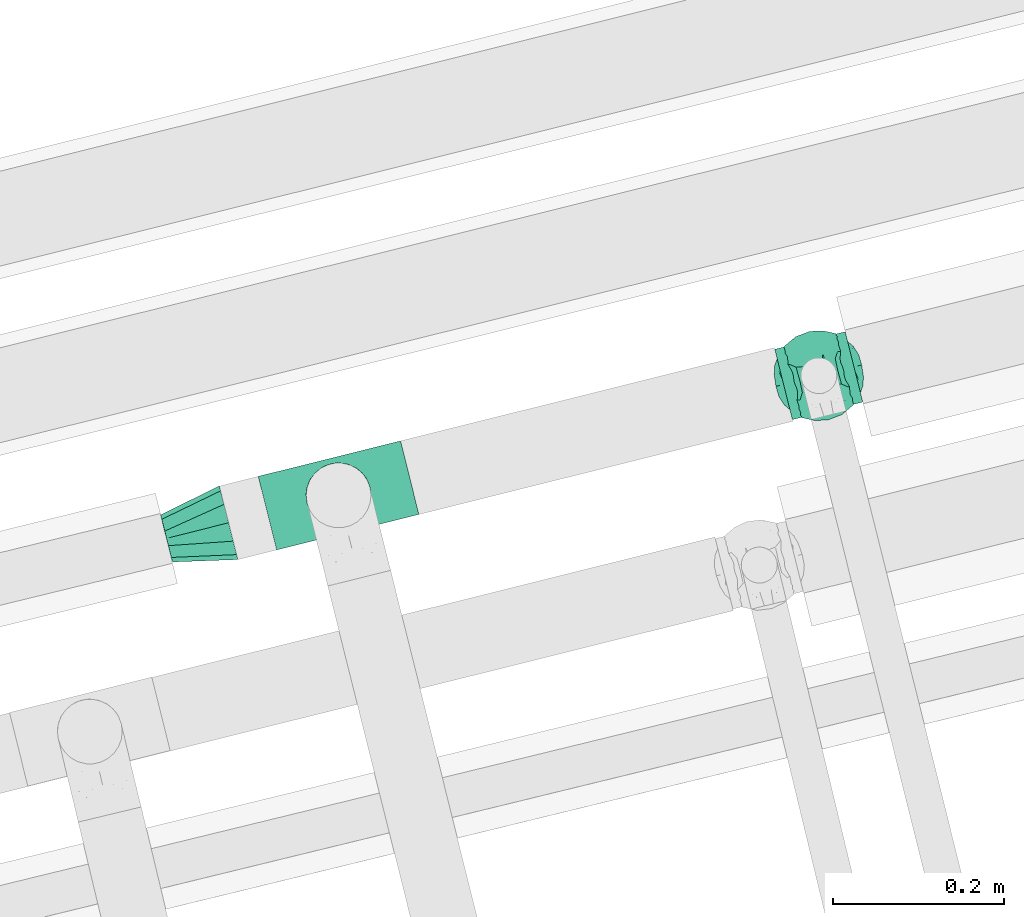
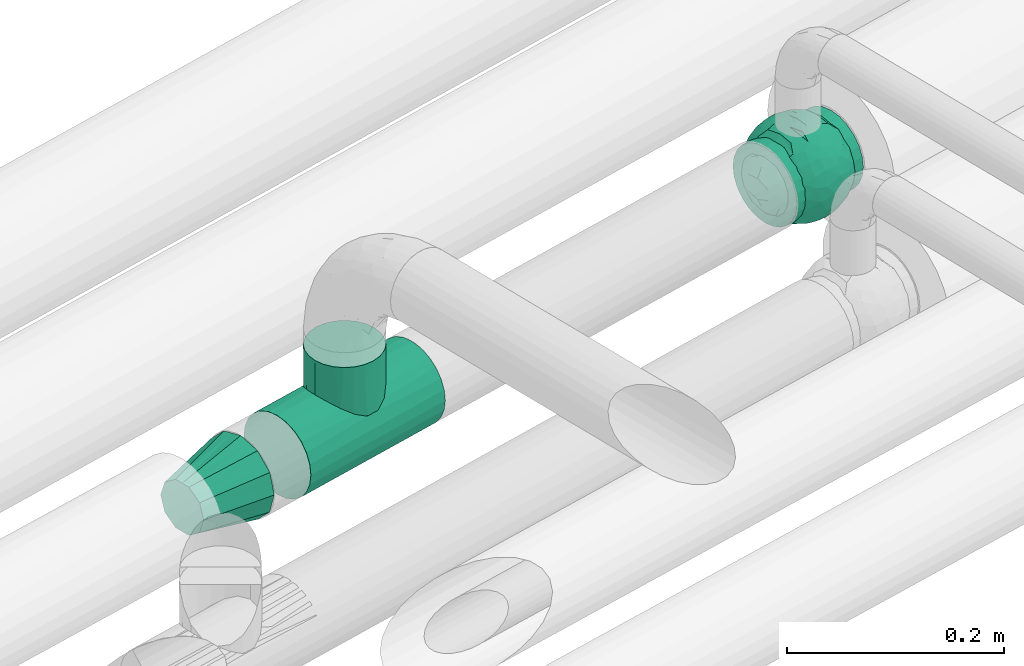
# One storey, part 88 of 93: 3 flow fittings.
"""IFC2X3 building model written with IfcOpenShell, lengths in millimetres."""

from ifc_helpers import new_model, entity, si_unit, converted_unit, derived_unit, direction, frame, origin, place, context, subcontext, project, spatial, faceted_brep, source, transform, mapped, material, material_list, type_object, type_shapes, element, save


model = new_model("IFC2X3")

# Units and contexts
model_context = context("Model", 3, precision=0.01, world=origin(), true_north=direction((6.12303176911189e-17, 1.0)))
body_context = subcontext(model_context, "Body", "Model", "MODEL_VIEW")
ifc_project = project(units=[si_unit("LENGTHUNIT", "METRE", prefix="MILLI"), si_unit("AREAUNIT", "SQUARE_METRE"), si_unit("VOLUMEUNIT", "CUBIC_METRE"), converted_unit("PLANEANGLEUNIT", "DEGREE", entity("IfcRatioMeasure", 0.0174532925199433), si_unit("PLANEANGLEUNIT", "RADIAN"), dimensions=[0, 0, 0, 0, 0, 0, 0]), si_unit("MASSUNIT", "GRAM", prefix="KILO"), derived_unit("MASSDENSITYUNIT", [(si_unit("MASSUNIT", "GRAM", prefix="KILO"), 1), (si_unit("LENGTHUNIT", "METRE"), -3)]), derived_unit("MOMENTOFINERTIAUNIT", [(si_unit("LENGTHUNIT", "METRE"), 4)]), si_unit("TIMEUNIT", "SECOND"), si_unit("FREQUENCYUNIT", "HERTZ"), si_unit("THERMODYNAMICTEMPERATUREUNIT", "DEGREE_CELSIUS"), derived_unit("THERMALTRANSMITTANCEUNIT", [(si_unit("MASSUNIT", "GRAM", prefix="KILO"), 1), (si_unit("THERMODYNAMICTEMPERATUREUNIT", "KELVIN"), -1), (si_unit("TIMEUNIT", "SECOND"), -3)]), derived_unit("VOLUMETRICFLOWRATEUNIT", [(si_unit("LENGTHUNIT", "METRE"), 3), (si_unit("TIMEUNIT", "SECOND"), -1)]), derived_unit("MASSFLOWRATEUNIT", [(si_unit("MASSUNIT", "GRAM", prefix="KILO"), 1), (si_unit("TIMEUNIT", "SECOND"), -1)]), derived_unit("ROTATIONALFREQUENCYUNIT", [(si_unit("TIMEUNIT", "SECOND"), -1)]), si_unit("ELECTRICCURRENTUNIT", "AMPERE"), si_unit("ELECTRICVOLTAGEUNIT", "VOLT"), si_unit("POWERUNIT", "WATT"), si_unit("FORCEUNIT", "NEWTON", prefix="KILO"), si_unit("ILLUMINANCEUNIT", "LUX"), si_unit("LUMINOUSFLUXUNIT", "LUMEN"), si_unit("LUMINOUSINTENSITYUNIT", "CANDELA"), derived_unit("USERDEFINED", [(si_unit("MASSUNIT", "GRAM", prefix="KILO"), -1), (si_unit("LENGTHUNIT", "METRE"), -2), (si_unit("TIMEUNIT", "SECOND"), 3), (si_unit("LUMINOUSFLUXUNIT", "LUMEN"), 1)]), derived_unit("LINEARVELOCITYUNIT", [(si_unit("LENGTHUNIT", "METRE"), 1), (si_unit("TIMEUNIT", "SECOND"), -1)]), si_unit("PRESSUREUNIT", "PASCAL"), derived_unit("USERDEFINED", [(si_unit("LENGTHUNIT", "METRE"), -2), (si_unit("MASSUNIT", "GRAM", prefix="KILO"), 1), (si_unit("TIMEUNIT", "SECOND"), -2)]), derived_unit("LINEARFORCEUNIT", [(si_unit("MASSUNIT", "GRAM", prefix="KILO"), 1), (si_unit("LENGTHUNIT", "METRE"), 1), (si_unit("TIMEUNIT", "SECOND"), -2), (si_unit("LENGTHUNIT", "METRE"), -1)]), derived_unit("PLANARFORCEUNIT", [(si_unit("MASSUNIT", "GRAM", prefix="KILO"), 1), (si_unit("LENGTHUNIT", "METRE"), 1), (si_unit("TIMEUNIT", "SECOND"), -2), (si_unit("LENGTHUNIT", "METRE"), -2)])], contexts=[model_context])

# Site, building, storey
site_placement = place(None, origin())
site = spatial("IfcSite", under=ifc_project, at=site_placement, CompositionType="ELEMENT")
building_placement = place(site_placement, origin())
building = spatial("IfcBuilding", under=site, at=building_placement, CompositionType="ELEMENT")
storey_placement = place(building_placement, frame((0.0, 0.0, -4200.0)))
storey = spatial("IfcBuildingStorey", under=building, at=storey_placement, CompositionType="ELEMENT", Elevation=-4200.0)

# Flow fittings
ifc_material_1 = material()
ifc_material_2 = material(Name="ADSK_")
ifc_material_list = material_list([ifc_material_1, ifc_material_2])
pipe_fitting_type_1 = type_object("IfcPipeFittingType", Name="ADSK_1", PredefinedType="NOTDEFINED", material=ifc_material_list)
shared_shape_1 = source(origin(), body_context, "Body", "Brep", [
    faceted_brep([(-42.5, -11.0, -41.05), (-42.5, -21.25, -36.81), (-42.5, -30.05, -30.05), (-42.5, -36.81, -21.25), (-42.5, -41.05, -11.0), (-42.5, -42.5, 0.0), (-42.5, -41.05, 11.0), (-42.5, -36.81, 21.25), (-42.5, -30.05, 30.05), (-42.5, -21.25, 36.81), (-42.5, -11.0, 41.05), (-42.5, 0.0, 42.5), (-42.5, 11.0, 41.05), (-42.5, 21.25, 36.81), (-42.5, 30.05, 30.05), (-42.5, 36.81, 21.25), (-42.5, 41.05, 11.0), (-42.5, 41.78, 5.5), (-42.5, 42.5, 0.0), (-42.5, 41.78, -5.5), (-42.5, 41.05, -11.0), (-42.5, 36.81, -21.25), (-42.5, 30.05, -30.05), (-42.5, 21.25, -36.81), (-42.5, 11.0, -41.05), (-42.5, 0.0, -42.5), (42.5, 0.0, -42.5), (42.5, 11.0, -41.05), (42.5, 21.25, -36.81), (42.5, 30.05, -30.05), (42.5, 36.81, -21.25), (42.5, 41.05, -11.0), (42.5, 41.78, -5.5), (42.5, 42.5, 0.0), (42.5, 41.78, 5.5), (42.5, 41.05, 11.0), (42.5, 36.81, 21.25), (42.5, 30.05, 30.05), (42.5, 21.25, 36.81), (42.5, 11.0, 41.05), (42.5, 0.0, 42.5), (42.5, -11.0, 41.05), (42.5, -21.25, 36.81), (42.5, -30.05, 30.05), (42.5, -36.81, 21.25), (42.5, -41.05, 11.0), (42.5, -42.5, 0.0), (42.5, -41.05, -11.0), (42.5, -36.81, -21.25), (42.5, -30.05, -30.05), (42.5, -21.25, -36.81), (42.5, -11.0, -41.05), (17.36, 42.02, 6.38), (18.5, 42.5, 0.0), (-18.5, 42.5, 0.0), (14.15, 40.8, 11.92), (3.25, 38.4, 18.21), (9.29, 39.37, 16.0), (6.27, 38.89, 17.11), (17.93, 42.26, 3.19), (-17.36, 42.02, 6.38), (-17.93, 42.26, 3.19), (-14.16, 40.8, 11.91), (-3.25, 38.4, 18.21), (-6.27, 38.89, 17.1), (-9.29, 39.37, 16.0), (0.0, 38.4, 18.21), (-17.93, 42.26, -3.19), (-17.36, 42.02, -6.38), (3.25, 38.4, -18.21), (17.36, 42.02, -6.38), (6.27, 38.89, -17.11), (9.29, 39.37, -16.0), (14.15, 40.8, -11.92), (17.93, 42.26, -3.19), (-9.29, 39.37, -16.0), (-6.27, 38.89, -17.1), (-3.25, 38.4, -18.21), (0.0, 38.4, -18.21), (-14.16, 40.8, -11.91), (4.79, 47.5, -17.87), (0.0, 47.5, -18.5), (-4.79, 47.5, -17.87), (-9.25, 47.5, -16.02), (-13.08, 47.5, -13.08), (-16.02, 47.5, -9.25), (-17.87, 47.5, -4.79), (-18.5, 47.5, 0.0), (-17.87, 47.5, 4.79), (-16.02, 47.5, 9.25), (-13.08, 47.5, 13.08), (-9.25, 47.5, 16.02), (-4.79, 47.5, 17.87), (0.0, 47.5, 18.5), (4.79, 47.5, 17.87), (9.25, 47.5, 16.02), (13.08, 47.5, 13.08), (16.02, 47.5, 9.25), (17.87, 47.5, 4.79), (18.5, 47.5, 0.0), (17.87, 47.5, -4.79), (16.02, 47.5, -9.25), (13.08, 47.5, -13.08), (9.25, 47.5, -16.02)], [[[0, 1, 2, 3, 4, 5, 6, 7, 8, 9, 10, 11, 12, 13, 14, 15, 16, 17, 18, 19, 20, 21, 22, 23, 24, 25]], [[26, 27, 28, 29, 30, 31, 32, 33, 34, 35, 36, 37, 38, 39, 40, 41, 42, 43, 44, 45, 46, 47, 48, 49, 50, 51]], [[52, 35, 34]], [[34, 33, 53]], [[17, 54, 18]], [[52, 55, 35]], [[56, 37, 36]], [[57, 35, 55]], [[36, 57, 58, 56]], [[56, 14, 37]], [[36, 35, 57]], [[34, 53, 59, 52]], [[17, 60, 61, 54]], [[16, 62, 60]], [[15, 63, 64, 65]], [[65, 16, 15]], [[14, 63, 15]], [[62, 16, 65]], [[14, 56, 66, 63]], [[17, 16, 60]], [[14, 13, 38, 37]], [[40, 39, 12, 11]], [[39, 38, 13, 12]], [[41, 40, 11, 10]], [[6, 45, 44, 7]], [[43, 42, 9, 8]], [[44, 43, 8, 7]], [[9, 42, 41, 10]], [[46, 45, 6, 5]], [[47, 46, 5, 4]], [[2, 49, 48, 3]], [[48, 47, 4, 3]], [[24, 27, 26, 25]], [[51, 50, 1, 0]], [[51, 0, 25, 26]], [[1, 50, 49, 2]], [[28, 27, 24, 23]], [[19, 54, 67, 68]], [[23, 22, 29, 28]], [[69, 30, 29]], [[32, 31, 70]], [[30, 69, 71, 72]], [[72, 31, 30]], [[22, 69, 29]], [[32, 53, 33]], [[18, 54, 19]], [[31, 73, 70]], [[32, 70, 74, 53]], [[72, 73, 31]], [[21, 75, 76, 77]], [[77, 22, 21]], [[21, 20, 75]], [[22, 77, 78, 69]], [[20, 68, 79]], [[20, 19, 68]], [[75, 20, 79]], [[80, 81, 82, 83, 84, 85, 86, 87, 88, 89, 90, 91, 92, 93, 94, 95, 96, 97, 98, 99, 100, 101, 102, 103]], [[87, 61, 88]], [[90, 89, 62]], [[60, 89, 88]], [[65, 91, 90]], [[61, 60, 88]], [[87, 54, 61]], [[62, 89, 60]], [[98, 52, 59]], [[64, 63, 92]], [[90, 62, 65]], [[66, 56, 93, 63]], [[94, 58, 95]], [[92, 63, 93]], [[94, 93, 56]], [[57, 95, 58]], [[97, 96, 55]], [[57, 96, 95]], [[98, 97, 52]], [[57, 55, 96]], [[58, 94, 56]], [[91, 65, 64]], [[98, 59, 99]], [[97, 55, 52]], [[53, 99, 59]], [[92, 91, 64]], [[99, 74, 100]], [[102, 101, 73]], [[70, 101, 100]], [[72, 103, 102]], [[74, 70, 100]], [[99, 53, 74]], [[73, 101, 70]], [[86, 68, 67]], [[71, 69, 80]], [[102, 73, 72]], [[78, 77, 81, 69]], [[82, 76, 83]], [[80, 69, 81]], [[82, 81, 77]], [[75, 83, 76]], [[85, 84, 79]], [[75, 84, 83]], [[86, 85, 68]], [[75, 79, 84]], [[76, 82, 77]], [[103, 72, 71]], [[86, 67, 87]], [[85, 79, 68]], [[54, 87, 67]], [[80, 103, 71]]]),
    faceted_brep([(51.28, 5.95, -12.54), (47.57, 0.0, -23.65), (46.38, 14.47, -21.49), (2.15, -2.87, -53.0), (12.28, 8.85, -50.92), (17.7, -5.66, -49.77), (-11.82, 29.03, -42.89), (-18.28, 40.66, -28.89), (-8.3, 38.19, -35.98), (40.06, 7.7, -34.03), (11.07, -18.92, -48.39), (20.41, -21.08, -44.28), (11.3, -28.17, -43.6), (51.07, -6.92, -12.89), (51.79, 0.0, 0.0), (-40.47, -3.74, -34.21), (-33.3, -12.91, -39.33), (-39.8, -12.92, -32.73), (51.79, -11.82, 0.0), (8.87, -37.57, -36.49), (18.57, -40.35, -29.15), (10.27, -45.23, -25.91), (30.17, -25.51, -35.52), (29.98, -13.37, -41.77), (39.0, -21.71, -28.82), (39.42, -8.24, -34.65), (27.67, -44.18, 0.0), (35.0, -34.14, -20.79), (36.91, -36.81, 0.0), (32.29, -40.49, 0.0), (-45.37, 12.95, -24.42), (-38.16, 9.26, -35.78), (-47.57, 0.0, -23.65), (8.06, 50.4, -14.75), (0.0, 51.83, -11.64), (5.76, 51.81, 0.0), (32.29, 40.49, 0.0), (42.51, 27.89, -15.42), (36.12, 33.63, -19.67), (-50.53, 9.19, -13.6), (46.66, 22.47, 0.0), (-44.16, -25.02, -15.71), (-46.66, -22.47, 0.0), (-50.52, -9.22, -13.61), (-45.35, -12.92, -24.47), (-39.0, -21.71, -28.82), (-0.05, 47.47, -23.85), (46.06, -13.95, -22.51), (3.12, 40.7, -34.0), (-10.28, 45.49, -25.44), (18.57, 40.35, -29.15), (11.24, 34.38, -38.91), (31.09, 0.0, -43.08), (31.25, 15.19, -40.19), (-37.82, -32.8, -17.79), (-36.91, -36.81, 0.0), (11.53, -50.49, 0.0), (16.36, -48.2, -15.2), (17.29, -49.18, 0.0), (-16.36, -48.2, -15.2), (-17.29, -49.18, 0.0), (-23.47, -44.9, -15.98), (-44.14, 25.04, -15.71), (-36.91, 36.81, 0.0), (-37.8, 32.81, -17.81), (-22.53, 31.78, -36.12), (-30.38, 38.01, -21.33), (-23.47, 44.9, -15.98), (28.22, 39.05, -22.38), (29.72, 28.61, -33.48), (-4.99, 13.62, -51.1), (0.0, 31.72, -42.62), (-3.95, 23.43, -47.52), (-20.38, -21.05, -44.31), (-11.38, -12.91, -50.26), (-9.33, -24.94, -45.97), (20.41, 21.08, -44.28), (10.92, 45.96, -24.31), (-11.53, 50.49, 0.0), (-16.38, 48.27, -14.96), (-17.29, 49.18, 0.0), (-32.29, 40.49, 0.0), (-27.67, 44.18, 0.0), (-23.05, 47.86, 0.0), (-30.36, 23.94, -36.43), (-28.59, 12.44, -43.01), (-15.25, -0.59, -50.89), (21.67, -31.55, -36.84), (27.5, -37.78, -25.27), (-0.05, -47.47, -23.85), (-2.02, -40.69, -34.1), (-10.14, -45.33, -25.77), (-18.28, -40.66, -28.89), (-10.75, -35.1, -38.4), (-30.38, -38.01, -21.33), (-23.05, -47.86, 0.0), (-27.67, -44.18, 0.0), (-32.29, -40.49, 0.0), (0.0, -31.72, -42.62), (0.98, -18.06, -49.95), (-30.21, -25.12, -35.76), (23.46, 45.39, -14.56), (0.0, 53.13, 0.0), (-8.48, -50.24, -15.03), (-5.76, -51.81, 0.0), (-11.53, -50.49, 0.0), (-41.53, 33.12, 0.0), (-39.0, 21.71, -28.82), (-21.3, -31.75, -36.88), (51.79, 11.82, 0.0), (39.0, 21.71, -28.82), (41.53, 33.12, 0.0), (46.66, -22.47, 0.0), (43.6, -26.01, -15.64), (22.77, 10.48, -46.84), (21.09, 32.2, -36.62), (27.67, 44.18, 0.0), (8.79, 24.03, -46.56), (-18.66, 10.27, -48.67), (-20.38, 21.05, -44.31), (-23.67, -8.98, -46.71), (-31.09, 0.0, -43.08), (23.05, 47.86, 0.0), (-8.24, 50.28, -15.03), (23.05, -47.86, 0.0), (23.47, -45.01, -15.67), (5.76, -51.81, 0.0), (8.44, -50.21, -15.18), (-46.66, 22.47, 0.0), (-41.53, -33.12, 0.0), (-51.79, -11.82, 0.0), (-51.79, 11.82, 0.0), (-51.79, 0.0, 0.0), (0.0, -51.81, -11.73), (0.0, -53.12, 0.0), (-5.76, 51.81, 0.0), (17.29, 49.18, 0.0), (11.53, 50.49, 0.0), (41.53, -33.12, 0.0), (36.91, 36.81, 0.0), (-51.28, 5.95, 12.54), (-47.57, 0.0, 23.65), (-46.38, 14.47, 21.49), (-2.15, -2.87, 53.0), (-12.28, 8.85, 50.92), (-17.7, -5.66, 49.77), (11.82, 29.03, 42.89), (18.28, 40.66, 28.89), (8.3, 38.19, 35.98), (-40.06, 7.7, 34.03), (-11.07, -18.92, 48.39), (-20.41, -21.08, 44.28), (-11.3, -28.17, 43.6), (-51.07, -6.92, 12.89), (40.47, -3.74, 34.21), (33.3, -12.91, 39.33), (39.8, -12.92, 32.73), (-8.87, -37.57, 36.49), (-18.57, -40.35, 29.15), (-10.27, -45.23, 25.91), (-30.17, -25.51, 35.52), (-29.98, -13.37, 41.77), (-39.0, -21.71, 28.82), (-39.42, -8.24, 34.65), (-35.0, -34.14, 20.79), (45.37, 12.95, 24.42), (38.16, 9.26, 35.78), (47.57, 0.0, 23.65), (-8.06, 50.4, 14.75), (0.0, 51.83, 11.64), (-42.51, 27.89, 15.42), (-36.12, 33.63, 19.67), (50.53, 9.19, 13.6), (44.16, -25.02, 15.71), (50.52, -9.22, 13.61), (45.35, -12.92, 24.47), (39.0, -21.71, 28.82), (0.05, 47.47, 23.85), (-46.06, -13.95, 22.51), (-3.12, 40.7, 34.0), (10.28, 45.49, 25.44), (-18.57, 40.35, 29.15), (-11.24, 34.38, 38.91), (-31.09, 0.0, 43.08), (-31.25, 15.19, 40.19), (37.82, -32.8, 17.79), (-16.36, -48.2, 15.2), (16.36, -48.2, 15.2), (23.47, -44.9, 15.98), (44.14, 25.04, 15.71), (37.8, 32.81, 17.81), (22.53, 31.78, 36.12), (30.38, 38.01, 21.33), (23.47, 44.9, 15.98), (-28.22, 39.05, 22.38), (-29.72, 28.61, 33.48), (4.99, 13.62, 51.1), (0.0, 31.72, 42.62), (3.95, 23.43, 47.52), (20.38, -21.05, 44.31), (11.38, -12.91, 50.26), (9.33, -24.94, 45.97), (-20.41, 21.08, 44.28), (-10.92, 45.96, 24.31), (16.38, 48.27, 14.96), (30.36, 23.94, 36.43), (28.59, 12.44, 43.01), (15.25, -0.59, 50.89), (-21.67, -31.55, 36.84), (-27.5, -37.78, 25.27), (0.05, -47.47, 23.85), (2.02, -40.69, 34.1), (10.14, -45.33, 25.77), (18.28, -40.66, 28.89), (10.75, -35.1, 38.4), (30.38, -38.01, 21.33), (0.0, -31.72, 42.62), (-0.98, -18.06, 49.95), (30.21, -25.12, 35.76), (-23.46, 45.39, 14.56), (8.48, -50.24, 15.03), (39.0, 21.71, 28.82), (21.3, -31.75, 36.88), (-39.0, 21.71, 28.82), (-43.6, -26.01, 15.64), (-22.77, 10.48, 46.84), (-21.09, 32.2, 36.62), (-8.79, 24.03, 46.56), (18.66, 10.27, 48.67), (20.38, 21.05, 44.31), (23.67, -8.98, 46.71), (31.09, 0.0, 43.08), (8.24, 50.28, 15.03), (-23.47, -45.01, 15.67), (-8.44, -50.21, 15.18), (0.0, -51.81, 11.73)], [[[0, 1, 2]], [[3, 4, 5]], [[6, 7, 8]], [[9, 2, 1]], [[10, 11, 12]], [[13, 0, 14]], [[15, 16, 17]], [[14, 18, 13]], [[19, 20, 21]], [[22, 23, 24]], [[25, 9, 1]], [[26, 27, 28, 29]], [[30, 31, 32]], [[33, 34, 35]], [[36, 37, 38]], [[32, 39, 30]], [[2, 40, 0]], [[25, 24, 23]], [[41, 42, 43]], [[44, 17, 45]], [[34, 33, 46]], [[47, 24, 25]], [[15, 32, 31]], [[46, 48, 49]], [[48, 50, 51]], [[9, 52, 53]], [[54, 55, 41]], [[56, 57, 58]], [[59, 60, 61]], [[62, 63, 64]], [[65, 7, 6]], [[66, 67, 7]], [[68, 38, 69]], [[4, 3, 70]], [[71, 72, 6]], [[73, 74, 75]], [[53, 76, 69]], [[48, 46, 77]], [[78, 79, 80]], [[49, 8, 7]], [[66, 81, 82, 83]], [[31, 84, 85]], [[66, 65, 84]], [[3, 86, 70]], [[11, 5, 23]], [[12, 87, 19]], [[87, 20, 19]], [[88, 22, 27]], [[89, 90, 21]], [[90, 89, 91]], [[92, 93, 91]], [[94, 95, 96, 97]], [[12, 98, 99]], [[45, 16, 100]], [[101, 50, 77]], [[34, 102, 35]], [[59, 91, 103]], [[59, 61, 92]], [[103, 104, 105]], [[63, 62, 106]], [[84, 31, 107]], [[108, 94, 100]], [[93, 92, 108]], [[45, 54, 41]], [[37, 40, 2]], [[109, 14, 0]], [[13, 1, 0]], [[2, 9, 110]], [[40, 109, 0]], [[111, 40, 37]], [[1, 13, 47]], [[47, 13, 112]], [[47, 112, 113]], [[13, 18, 112]], [[113, 24, 47]], [[110, 9, 53]], [[9, 25, 52]], [[1, 47, 25]], [[52, 25, 23]], [[110, 53, 69]], [[114, 4, 76]], [[68, 115, 50]], [[50, 115, 51]], [[69, 38, 110]], [[52, 23, 5]], [[22, 11, 23]], [[114, 76, 53]], [[3, 10, 99]], [[22, 87, 11]], [[24, 27, 22]], [[22, 88, 87]], [[68, 116, 38]], [[113, 28, 27]], [[52, 5, 114]], [[117, 115, 76]], [[117, 4, 70]], [[118, 85, 119]], [[119, 70, 118]], [[120, 16, 121]], [[110, 38, 37]], [[36, 38, 116]], [[68, 122, 116]], [[46, 123, 34]], [[11, 87, 12]], [[88, 20, 87]], [[12, 99, 10]], [[19, 98, 12]], [[86, 3, 74]], [[108, 73, 75]], [[124, 58, 125]], [[88, 26, 125]], [[98, 19, 90]], [[21, 90, 19]], [[98, 90, 93]], [[91, 93, 90]], [[56, 126, 127]], [[27, 26, 88]], [[125, 57, 20]], [[125, 20, 88]], [[21, 20, 57]], [[98, 93, 75]], [[108, 75, 93]], [[75, 99, 98]], [[120, 86, 74]], [[74, 99, 75]], [[99, 74, 3]], [[73, 108, 100]], [[108, 92, 94]], [[120, 121, 86]], [[54, 45, 100]], [[100, 16, 73]], [[121, 16, 15]], [[121, 15, 31]], [[44, 32, 15]], [[121, 31, 85]], [[30, 107, 31]], [[32, 44, 43]], [[44, 45, 41]], [[30, 62, 107]], [[128, 62, 39]], [[43, 39, 32]], [[42, 41, 129]], [[42, 130, 43]], [[43, 44, 41]], [[63, 81, 64]], [[54, 94, 97]], [[94, 54, 100]], [[64, 107, 62]], [[128, 39, 131]], [[128, 106, 62]], [[107, 64, 84]], [[64, 81, 66]], [[62, 30, 39]], [[132, 43, 130]], [[60, 95, 61]], [[133, 126, 134]], [[95, 94, 61]], [[60, 59, 105]], [[92, 61, 94]], [[126, 133, 127]], [[57, 56, 127]], [[127, 89, 21]], [[134, 104, 133]], [[133, 89, 127]], [[91, 89, 103]], [[103, 133, 104]], [[133, 103, 89]], [[86, 121, 118]], [[84, 119, 85]], [[119, 84, 65]], [[66, 84, 64]], [[119, 65, 6]], [[7, 65, 66]], [[70, 119, 72]], [[8, 71, 6]], [[71, 8, 48]], [[49, 48, 8]], [[71, 48, 51]], [[50, 48, 77]], [[122, 68, 101]], [[135, 34, 123]], [[136, 122, 101]], [[136, 77, 137]], [[67, 83, 80]], [[67, 79, 7]], [[83, 67, 66]], [[49, 7, 79]], [[35, 137, 33]], [[79, 78, 123]], [[102, 34, 135]], [[77, 46, 33]], [[135, 123, 78]], [[49, 123, 46]], [[71, 51, 117]], [[69, 76, 115]], [[72, 71, 117]], [[117, 76, 4]], [[43, 132, 39]], [[132, 131, 39]], [[77, 33, 137]], [[58, 57, 125]], [[21, 57, 127]], [[105, 59, 103]], [[92, 91, 59]], [[136, 101, 77]], [[101, 68, 50]], [[24, 113, 27]], [[138, 113, 112]], [[120, 73, 16]], [[73, 120, 74]], [[80, 79, 67]], [[49, 79, 123]], [[110, 37, 2]], [[37, 36, 139, 111]], [[124, 125, 26]], [[117, 51, 115]], [[69, 115, 68]], [[85, 118, 121]], [[86, 118, 70]], [[10, 5, 11]], [[5, 10, 3]], [[6, 72, 119]], [[70, 72, 117]], [[4, 114, 5]], [[114, 53, 52]], [[113, 138, 28]], [[15, 17, 44]], [[17, 16, 45]], [[97, 55, 54]], [[55, 129, 41]], [[140, 141, 142]], [[143, 144, 145]], [[146, 147, 148]], [[149, 142, 141]], [[150, 151, 152]], [[153, 140, 132]], [[154, 155, 156]], [[132, 130, 153]], [[157, 158, 159]], [[160, 161, 162]], [[163, 149, 141]], [[96, 164, 55, 97]], [[165, 166, 167]], [[168, 169, 135]], [[81, 170, 171]], [[167, 172, 165]], [[142, 128, 140]], [[163, 162, 161]], [[173, 112, 174]], [[175, 156, 176]], [[169, 168, 177]], [[178, 162, 163]], [[154, 167, 166]], [[177, 179, 180]], [[179, 181, 182]], [[149, 183, 184]], [[185, 28, 173]], [[105, 186, 60]], [[187, 58, 188]], [[189, 139, 190]], [[191, 147, 146]], [[192, 193, 147]], [[194, 171, 195]], [[144, 143, 196]], [[197, 198, 146]], [[199, 200, 201]], [[184, 202, 195]], [[179, 177, 203]], [[137, 204, 136]], [[180, 148, 147]], [[192, 36, 116, 122]], [[166, 205, 206]], [[192, 191, 205]], [[143, 207, 196]], [[151, 145, 161]], [[152, 208, 157]], [[208, 158, 157]], [[209, 160, 164]], [[210, 211, 159]], [[211, 210, 212]], [[213, 214, 212]], [[215, 124, 26, 29]], [[152, 216, 217]], [[176, 155, 218]], [[219, 181, 203]], [[169, 102, 135]], [[187, 212, 220]], [[187, 188, 213]], [[220, 126, 56]], [[139, 189, 111]], [[205, 166, 221]], [[222, 215, 218]], [[214, 213, 222]], [[176, 185, 173]], [[170, 128, 142]], [[131, 132, 140]], [[153, 141, 140]], [[142, 149, 223]], [[128, 131, 140]], [[106, 128, 170]], [[141, 153, 178]], [[178, 153, 42]], [[178, 42, 224]], [[153, 130, 42]], [[224, 162, 178]], [[223, 149, 184]], [[149, 163, 183]], [[141, 178, 163]], [[183, 163, 161]], [[223, 184, 195]], [[225, 144, 202]], [[194, 226, 181]], [[181, 226, 182]], [[195, 171, 223]], [[183, 161, 145]], [[160, 151, 161]], [[225, 202, 184]], [[143, 150, 217]], [[160, 208, 151]], [[162, 164, 160]], [[160, 209, 208]], [[194, 82, 171]], [[224, 55, 164]], [[183, 145, 225]], [[227, 226, 202]], [[227, 144, 196]], [[228, 206, 229]], [[229, 196, 228]], [[230, 155, 231]], [[223, 171, 170]], [[81, 171, 82]], [[194, 83, 82]], [[177, 232, 169]], [[151, 208, 152]], [[209, 158, 208]], [[152, 217, 150]], [[157, 216, 152]], [[207, 143, 200]], [[222, 199, 201]], [[95, 60, 233]], [[209, 96, 233]], [[216, 157, 211]], [[159, 211, 157]], [[216, 211, 214]], [[212, 214, 211]], [[105, 104, 234]], [[164, 96, 209]], [[233, 186, 158]], [[233, 158, 209]], [[159, 158, 186]], [[216, 214, 201]], [[222, 201, 214]], [[201, 217, 216]], [[230, 207, 200]], [[200, 217, 201]], [[217, 200, 143]], [[199, 222, 218]], [[222, 213, 215]], [[230, 231, 207]], [[185, 176, 218]], [[218, 155, 199]], [[231, 155, 154]], [[231, 154, 166]], [[175, 167, 154]], [[231, 166, 206]], [[165, 221, 166]], [[167, 175, 174]], [[175, 176, 173]], [[165, 189, 221]], [[40, 189, 172]], [[174, 172, 167]], [[112, 173, 138]], [[112, 18, 174]], [[174, 175, 173]], [[139, 36, 190]], [[185, 215, 29]], [[215, 185, 218]], [[190, 221, 189]], [[40, 172, 109]], [[40, 111, 189]], [[221, 190, 205]], [[190, 36, 192]], [[189, 165, 172]], [[14, 174, 18]], [[58, 124, 188]], [[235, 104, 134]], [[124, 215, 188]], [[58, 187, 56]], [[213, 188, 215]], [[104, 235, 234]], [[186, 105, 234]], [[234, 210, 159]], [[134, 126, 235]], [[235, 210, 234]], [[212, 210, 220]], [[220, 235, 126]], [[235, 220, 210]], [[207, 231, 228]], [[205, 229, 206]], [[229, 205, 191]], [[192, 205, 190]], [[229, 191, 146]], [[147, 191, 192]], [[196, 229, 198]], [[148, 197, 146]], [[197, 148, 179]], [[180, 179, 148]], [[197, 179, 182]], [[181, 179, 203]], [[83, 194, 219]], [[35, 169, 232]], [[80, 83, 219]], [[80, 203, 78]], [[193, 122, 136]], [[193, 204, 147]], [[122, 193, 192]], [[180, 147, 204]], [[135, 78, 168]], [[204, 137, 232]], [[102, 169, 35]], [[203, 177, 168]], [[35, 232, 137]], [[180, 232, 177]], [[197, 182, 227]], [[195, 202, 226]], [[198, 197, 227]], [[227, 202, 144]], [[174, 14, 172]], [[14, 109, 172]], [[203, 168, 78]], [[60, 186, 233]], [[159, 186, 234]], [[56, 187, 220]], [[213, 212, 187]], [[80, 219, 203]], [[219, 194, 181]], [[162, 224, 164]], [[129, 224, 42]], [[230, 199, 155]], [[199, 230, 200]], [[136, 204, 193]], [[180, 204, 232]], [[223, 170, 142]], [[170, 81, 63, 106]], [[95, 233, 96]], [[227, 182, 226]], [[195, 226, 194]], [[206, 228, 231]], [[207, 228, 196]], [[150, 145, 151]], [[145, 150, 143]], [[146, 198, 229]], [[196, 198, 227]], [[144, 225, 145]], [[225, 184, 183]], [[224, 129, 55]], [[154, 156, 175]], [[156, 155, 176]], [[29, 28, 185]], [[28, 138, 173]]]),
])
type_shapes(pipe_fitting_type_1, [shared_shape_1])
flow_fitting_1_placement = place(storey_placement, frame((-10773.89, 12755.59, 2500.3), z_axis=(0.241921895080684, -0.970295726405394, 0.0), x_axis=(0.970295726405394, 0.241921895080684, 0.0)))
element("IfcFlowFitting", 1, at=flow_fitting_1_placement, inside=storey, type_object=pipe_fitting_type_1, material=ifc_material_list, Name="ADSK_1", ObjectType="ADSK_1", context=body_context, shape_type="MappedRepresentation", body=[
    mapped(shared_shape_1, transform((0.0, 0.0, 0.0), scale=1.0)),
])
pipe_fitting_type_2 = type_object("IfcPipeFittingType", Name="ADSK_1", PredefinedType="NOTDEFINED", material=ifc_material_1)
shared_shape_2 = source(origin(), body_context, "Body", "Brep", [
    faceted_brep([(-86.0, 0.0, -44.45), (-86.0, -11.5, -42.94), (-86.0, -22.22, -38.49), (-86.0, -31.43, -31.43), (-86.0, -38.49, -22.23), (-86.0, -42.94, -11.5), (-86.0, -44.45, 0.0), (-86.0, -42.94, 11.5), (-86.0, -38.49, 22.22), (-86.0, -31.43, 31.43), (-86.0, -22.22, 38.49), (-86.0, -11.5, 42.94), (-86.0, 0.0, 44.45), (-86.0, 11.5, 42.94), (-86.0, 22.23, 38.49), (-86.0, 31.43, 31.43), (-86.0, 34.96, 26.83), (-86.0, 38.49, 22.22), (-86.0, 40.72, 16.86), (-86.0, 42.94, 11.5), (-86.0, 43.69, 5.75), (-86.0, 44.45, 0.0), (-86.0, 43.69, -5.75), (-86.0, 42.94, -11.5), (-86.0, 40.72, -16.86), (-86.0, 38.49, -22.23), (-86.0, 34.96, -26.83), (-86.0, 31.43, -31.43), (-86.0, 22.23, -38.49), (-86.0, 11.5, -42.94), (86.0, -22.22, -38.49), (86.0, -11.5, -42.94), (86.0, 0.0, -44.45), (86.0, 11.5, -42.94), (86.0, 22.23, -38.49), (86.0, 31.43, -31.43), (86.0, 34.96, -26.83), (86.0, 38.49, -22.23), (86.0, 40.72, -16.86), (86.0, 42.94, -11.5), (86.0, 43.69, -5.75), (86.0, 44.45, 0.0), (86.0, 43.69, 5.75), (86.0, 42.94, 11.5), (86.0, 40.72, 16.86), (86.0, 38.49, 22.22), (86.0, 34.96, 26.83), (86.0, 31.43, 31.43), (86.0, 22.23, 38.49), (86.0, 11.5, 42.94), (86.0, 0.0, 44.45), (86.0, -11.5, 42.94), (86.0, -22.22, 38.49), (86.0, -31.43, 31.43), (86.0, -38.49, 22.22), (86.0, -42.94, 11.5), (86.0, -44.45, 0.0), (86.0, -42.94, -11.5), (86.0, -38.49, -22.23), (86.0, -31.43, -31.43), (36.76, 43.36, 6.88), (-32.1, 39.52, 19.35), (38.05, 44.45, 0.0), (-38.05, 44.45, 0.0), (32.1, 39.52, 19.36), (28.71, 36.78, 24.97), (19.13, 29.9, 32.89), (7.0, 24.02, 37.4), (-35.48, 42.27, 13.74), (35.48, 42.27, 13.75), (-36.77, 43.36, 6.87), (-28.71, 36.78, 24.97), (-19.13, 29.9, 32.89), (-7.02, 24.03, 37.4), (-0.01, 24.02, 37.4), (-36.77, 43.36, -6.87), (7.0, 24.02, -37.4), (-28.71, 36.78, -24.97), (36.76, 43.36, -6.88), (-7.02, 24.03, -37.4), (19.13, 29.9, -32.89), (28.71, 36.78, -24.97), (-35.48, 42.27, -13.74), (35.48, 42.27, -13.75), (32.1, 39.52, -19.36), (-32.1, 39.52, -19.35), (-19.13, 29.9, -32.89), (-0.01, 24.02, -37.4), (0.0, 83.0, -38.05), (-9.85, 83.0, -36.75), (-19.02, 83.0, -32.95), (-26.91, 83.0, -26.91), (-32.95, 83.0, -19.03), (-36.75, 83.0, -9.85), (-38.05, 83.0, 0.0), (-36.75, 83.0, 9.85), (-32.95, 83.0, 19.02), (-26.91, 83.0, 26.91), (-19.02, 83.0, 32.95), (-9.85, 83.0, 36.75), (0.0, 83.0, 38.05), (9.85, 83.0, 36.75), (19.03, 83.0, 32.95), (26.91, 83.0, 26.91), (32.95, 83.0, 19.02), (36.75, 83.0, 9.85), (38.05, 83.0, 0.0), (36.75, 83.0, -9.85), (32.95, 83.0, -19.03), (26.91, 83.0, -26.91), (19.03, 83.0, -32.95), (9.85, 83.0, -36.75)], [[[0, 1, 2, 3, 4, 5, 6, 7, 8, 9, 10, 11, 12, 13, 14, 15, 16, 17, 18, 19, 20, 21, 22, 23, 24, 25, 26, 27, 28, 29]], [[30, 31, 32, 33, 34, 35, 36, 37, 38, 39, 40, 41, 42, 43, 44, 45, 46, 47, 48, 49, 50, 51, 52, 53, 54, 55, 56, 57, 58, 59]], [[42, 60, 43]], [[18, 17, 61]], [[62, 42, 41]], [[21, 20, 63]], [[45, 64, 65]], [[46, 66, 47]], [[44, 64, 45]], [[66, 46, 65]], [[66, 67, 48]], [[19, 18, 68]], [[48, 47, 66]], [[44, 69, 64]], [[46, 45, 65]], [[19, 68, 70]], [[71, 16, 72]], [[60, 42, 62]], [[20, 70, 63]], [[61, 68, 18]], [[20, 19, 70]], [[14, 72, 15]], [[60, 69, 43]], [[16, 71, 17]], [[61, 17, 71]], [[15, 72, 16]], [[14, 73, 72]], [[44, 43, 69]], [[13, 67, 74, 73]], [[50, 49, 13, 12]], [[13, 49, 67]], [[51, 50, 12, 11]], [[7, 55, 54, 8]], [[53, 52, 10, 9]], [[54, 53, 9, 8]], [[10, 52, 51, 11]], [[56, 55, 7, 6]], [[14, 13, 73]], [[49, 48, 67]], [[5, 4, 58, 57]], [[75, 22, 63]], [[3, 59, 58, 4]], [[6, 5, 57, 56]], [[29, 33, 32, 0]], [[31, 30, 2, 1]], [[32, 31, 1, 0]], [[2, 30, 59, 3]], [[29, 76, 33]], [[26, 25, 77]], [[40, 39, 78]], [[29, 28, 79]], [[76, 34, 33]], [[35, 80, 36]], [[37, 36, 81]], [[75, 82, 23]], [[80, 34, 76]], [[41, 40, 62]], [[63, 22, 21]], [[35, 34, 80]], [[40, 78, 62]], [[83, 38, 84]], [[78, 39, 83]], [[38, 37, 84]], [[81, 84, 37]], [[85, 24, 82]], [[28, 27, 86]], [[85, 77, 25]], [[27, 26, 86]], [[77, 86, 26]], [[39, 38, 83]], [[79, 28, 86]], [[81, 36, 80]], [[85, 25, 24]], [[23, 22, 75]], [[23, 82, 24]], [[29, 79, 87, 76]], [[88, 89, 90, 91, 92, 93, 94, 95, 96, 97, 98, 99, 100, 101, 102, 103, 104, 105, 106, 107, 108, 109, 110, 111]], [[96, 95, 68]], [[98, 97, 72]], [[71, 97, 96]], [[99, 98, 72]], [[95, 94, 70]], [[70, 94, 63]], [[70, 68, 95]], [[96, 68, 61, 71]], [[71, 72, 97]], [[62, 106, 60]], [[72, 73, 99]], [[74, 67, 100, 73]], [[102, 101, 66]], [[102, 66, 103]], [[105, 104, 69]], [[65, 104, 103]], [[101, 100, 67]], [[67, 66, 101]], [[99, 73, 100]], [[65, 103, 66]], [[104, 65, 64, 69]], [[105, 69, 60]], [[105, 60, 106]], [[106, 78, 107]], [[93, 82, 75]], [[111, 76, 88]], [[63, 94, 75]], [[78, 83, 107]], [[83, 108, 107]], [[108, 81, 109]], [[106, 62, 78]], [[108, 83, 84, 81]], [[80, 111, 110]], [[109, 81, 80]], [[76, 111, 80]], [[110, 109, 80]], [[87, 79, 88, 76]], [[90, 89, 86]], [[90, 86, 91]], [[93, 92, 82]], [[77, 92, 91]], [[89, 88, 79]], [[79, 86, 89]], [[77, 91, 86]], [[92, 77, 85, 82]], [[93, 75, 94]]]),
])
type_shapes(pipe_fitting_type_2, [shared_shape_2])
flow_fitting_2_placement = place(storey_placement, frame((-11337.02, 12615.18, 2500.3), z_axis=(0.241921895080684, -0.970295726405394, 0.0), x_axis=(0.970295726405394, 0.241921895080684, 0.0)))
element("IfcFlowFitting", 2, at=flow_fitting_2_placement, inside=storey, type_object=pipe_fitting_type_2, material=ifc_material_1, Name="ADSK_1", ObjectType="ADSK_1", context=body_context, shape_type="MappedRepresentation", body=[
    mapped(shared_shape_2, transform((0.0, 0.0, 0.0), scale=1.0)),
])
pipe_fitting_type_3 = type_object("IfcPipeFittingType", Name="ADSK_2", PredefinedType="NOTDEFINED", material=ifc_material_1)
shared_shape_3 = source(origin(), body_context, "Body", "Brep", [
    faceted_brep([(75.0, 23.06, 16.75), (75.0, 15.93, 21.93), (75.0, 8.81, 27.11), (75.0, 0.0, 27.11), (75.0, -8.81, 27.11), (75.0, -15.93, 21.93), (75.0, -23.06, 16.75), (75.0, -25.78, 8.38), (75.0, -28.5, 0.0), (75.0, -25.78, -8.38), (75.0, -23.06, -16.75), (75.0, -15.93, -21.93), (75.0, -8.81, -27.11), (75.0, 0.0, -27.11), (75.0, 8.81, -27.11), (75.0, 15.93, -21.93), (75.0, 23.06, -16.75), (75.0, 25.78, -8.38), (75.0, 28.5, 0.0), (75.0, 25.78, 8.38), (0.0, 11.12, 41.52), (0.0, 22.25, 38.54), (0.0, 30.39, 30.39), (0.0, 38.54, 22.25), (0.0, 41.77, 10.2), (0.0, 44.5, 0.0), (0.0, 41.77, -10.2), (0.0, 38.54, -22.25), (0.0, 30.39, -30.39), (0.0, 22.25, -38.54), (0.0, 11.13, -41.52), (0.0, 0.0, -44.5), (0.0, -11.13, -41.52), (0.0, -22.25, -38.54), (0.0, -30.39, -30.39), (0.0, -38.54, -22.25), (0.0, -41.77, -10.2), (0.0, -44.5, 0.0), (0.0, -41.77, 10.2), (0.0, -38.54, 22.25), (0.0, -30.39, 30.39), (0.0, -22.25, 38.54), (0.0, -11.12, 41.52), (0.0, 0.0, 44.5)], [[[0, 1, 2, 3, 4, 5, 6, 7, 8, 9, 10, 11, 12, 13, 14, 15, 16, 17, 18, 19]], [[20, 21, 22, 23, 24, 25, 26, 27, 28, 29, 30, 31, 32, 33, 34, 35, 36, 37, 38, 39, 40, 41, 42, 43]], [[35, 9, 36]], [[30, 29, 14]], [[15, 28, 16]], [[27, 17, 16]], [[26, 18, 17]], [[33, 12, 11]], [[28, 15, 29]], [[27, 16, 28]], [[12, 32, 13]], [[14, 13, 30]], [[10, 34, 11]], [[15, 14, 29]], [[32, 31, 13]], [[8, 36, 9]], [[27, 26, 17]], [[12, 33, 32]], [[18, 26, 25]], [[9, 35, 10]], [[10, 35, 34]], [[8, 37, 36]], [[33, 11, 34]], [[30, 13, 31]], [[23, 19, 24]], [[42, 41, 4]], [[5, 40, 6]], [[39, 7, 6]], [[38, 8, 7]], [[21, 2, 1]], [[40, 5, 41]], [[39, 6, 40]], [[2, 20, 3]], [[4, 3, 42]], [[0, 22, 1]], [[5, 4, 41]], [[20, 43, 3]], [[18, 24, 19]], [[39, 38, 7]], [[2, 21, 20]], [[8, 38, 37]], [[19, 23, 0]], [[0, 23, 22]], [[18, 25, 24]], [[21, 1, 22]], [[42, 3, 43]]]),
])
type_shapes(pipe_fitting_type_3, [shared_shape_3])
flow_fitting_3_placement = place(storey_placement, frame((-11466.06, 12583.09, 2500.59), z_axis=(0.00368563653770174, 0.000929064340453061, 0.999992776435292), x_axis=(-0.969659753374151, -0.244428958204922, 0.00380093110128868)))
element("IfcFlowFitting", 3, at=flow_fitting_3_placement, inside=storey, type_object=pipe_fitting_type_3, material=ifc_material_1, Name="ADSK_2", ObjectType="ADSK_2", context=body_context, shape_type="MappedRepresentation", body=[
    mapped(shared_shape_3, transform((0.0, 0.0, 0.0), scale=1.0)),
])

save(model, "model.ifc")
